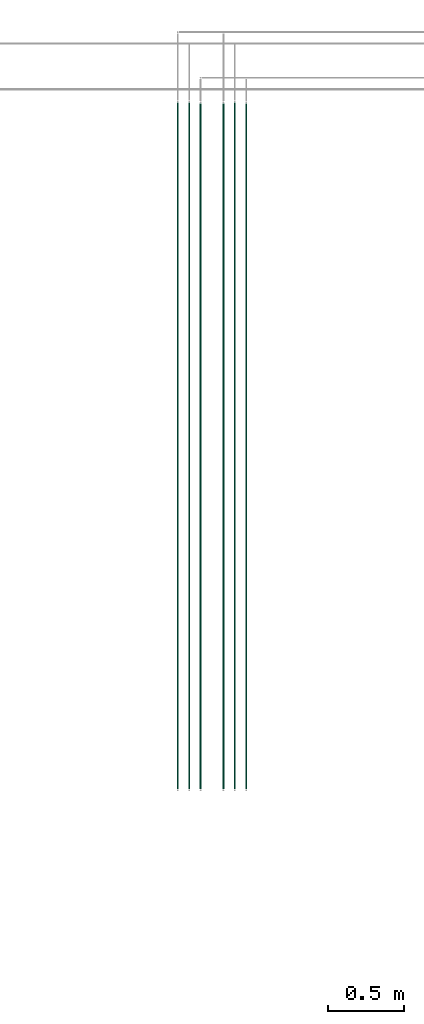
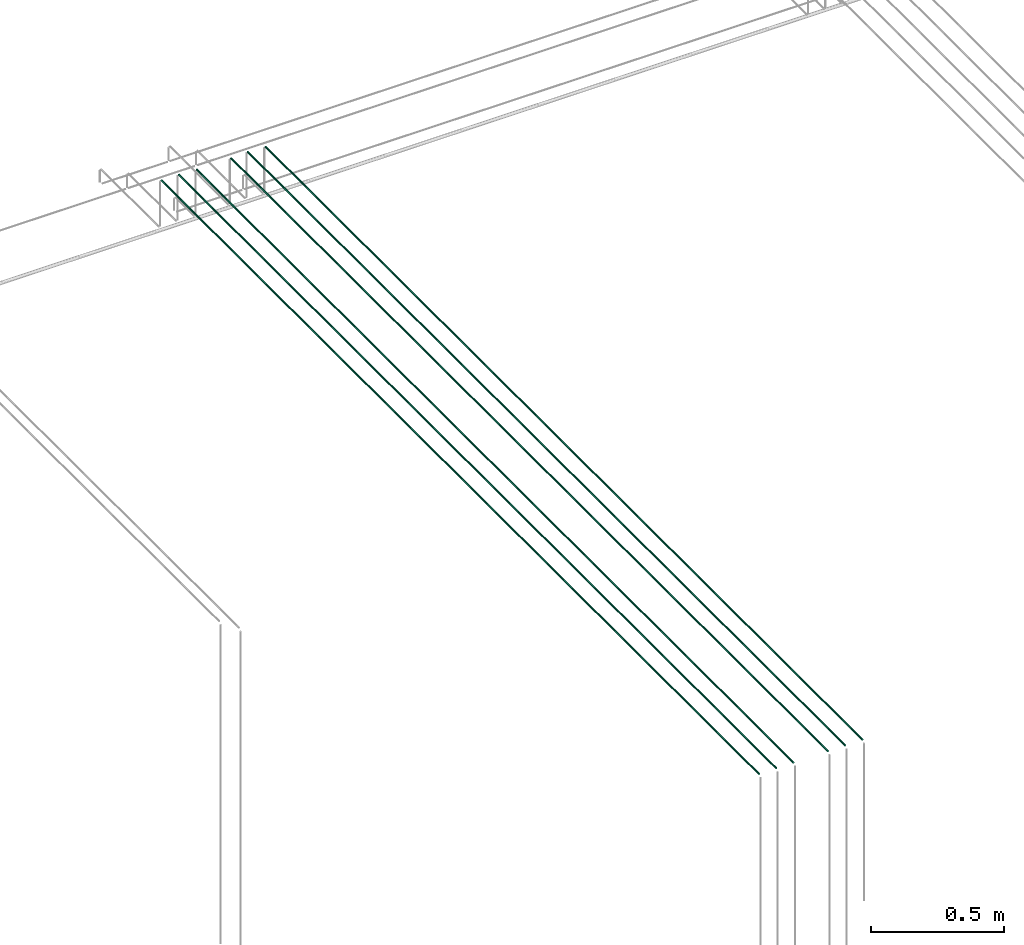
# One storey, part 8 of 89: 6 flow segments.
"""IFC2X3 building model written with IfcOpenShell, lengths in millimetres."""

from ifc_helpers import new_model, entity, si_unit, converted_unit, derived_unit, direction, frame, origin, origin_2d_with_axis, place, context, subcontext, project, spatial, circle, extrude, type_object, element, save


model = new_model("IFC2X3")

# Units and contexts
model_context = context("Model", 3, precision=0.01, world=origin(), true_north=direction((6.12303176911189e-17, 1.0)))
body_context = subcontext(model_context, "Body", "Model", "MODEL_VIEW")
ifc_project = project(units=[si_unit("LENGTHUNIT", "METRE", prefix="MILLI"), si_unit("AREAUNIT", "SQUARE_METRE"), si_unit("VOLUMEUNIT", "CUBIC_METRE"), converted_unit("PLANEANGLEUNIT", "DEGREE", entity("IfcRatioMeasure", 0.0174532925199433), si_unit("PLANEANGLEUNIT", "RADIAN"), dimensions=[0, 0, 0, 0, 0, 0, 0]), si_unit("MASSUNIT", "GRAM", prefix="KILO"), derived_unit("MASSDENSITYUNIT", [(si_unit("MASSUNIT", "GRAM", prefix="KILO"), 1), (si_unit("LENGTHUNIT", "METRE"), -3)]), derived_unit("MOMENTOFINERTIAUNIT", [(si_unit("LENGTHUNIT", "METRE"), 4)]), si_unit("TIMEUNIT", "SECOND"), si_unit("FREQUENCYUNIT", "HERTZ"), si_unit("THERMODYNAMICTEMPERATUREUNIT", "DEGREE_CELSIUS"), derived_unit("THERMALTRANSMITTANCEUNIT", [(si_unit("MASSUNIT", "GRAM", prefix="KILO"), 1), (si_unit("THERMODYNAMICTEMPERATUREUNIT", "KELVIN"), -1), (si_unit("TIMEUNIT", "SECOND"), -3)]), derived_unit("VOLUMETRICFLOWRATEUNIT", [(si_unit("LENGTHUNIT", "METRE"), 3), (si_unit("TIMEUNIT", "SECOND"), -1)]), derived_unit("MASSFLOWRATEUNIT", [(si_unit("MASSUNIT", "GRAM", prefix="KILO"), 1), (si_unit("TIMEUNIT", "SECOND"), -1)]), derived_unit("ROTATIONALFREQUENCYUNIT", [(si_unit("TIMEUNIT", "SECOND"), -1)]), si_unit("ELECTRICCURRENTUNIT", "AMPERE"), si_unit("ELECTRICVOLTAGEUNIT", "VOLT"), si_unit("POWERUNIT", "WATT"), si_unit("FORCEUNIT", "NEWTON", prefix="KILO"), si_unit("ILLUMINANCEUNIT", "LUX"), si_unit("LUMINOUSFLUXUNIT", "LUMEN"), si_unit("LUMINOUSINTENSITYUNIT", "CANDELA"), derived_unit("USERDEFINED", [(si_unit("MASSUNIT", "GRAM", prefix="KILO"), -1), (si_unit("LENGTHUNIT", "METRE"), -2), (si_unit("TIMEUNIT", "SECOND"), 3), (si_unit("LUMINOUSFLUXUNIT", "LUMEN"), 1)]), derived_unit("LINEARVELOCITYUNIT", [(si_unit("LENGTHUNIT", "METRE"), 1), (si_unit("TIMEUNIT", "SECOND"), -1)]), si_unit("PRESSUREUNIT", "PASCAL"), derived_unit("USERDEFINED", [(si_unit("LENGTHUNIT", "METRE"), -2), (si_unit("MASSUNIT", "GRAM", prefix="KILO"), 1), (si_unit("TIMEUNIT", "SECOND"), -2)]), derived_unit("LINEARFORCEUNIT", [(si_unit("MASSUNIT", "GRAM", prefix="KILO"), 1), (si_unit("LENGTHUNIT", "METRE"), 1), (si_unit("TIMEUNIT", "SECOND"), -2), (si_unit("LENGTHUNIT", "METRE"), -1)]), derived_unit("PLANARFORCEUNIT", [(si_unit("MASSUNIT", "GRAM", prefix="KILO"), 1), (si_unit("LENGTHUNIT", "METRE"), 1), (si_unit("TIMEUNIT", "SECOND"), -2), (si_unit("LENGTHUNIT", "METRE"), -2)])], contexts=[model_context])

# Site, building, storey
site_placement = place(None, frame((0.0, -0.00077364408347762, 0.0)))
site = spatial("IfcSite", under=ifc_project, at=site_placement, CompositionType="ELEMENT")
building_placement = place(site_placement, origin())
building = spatial("IfcBuilding", under=site, at=building_placement, CompositionType="ELEMENT")
storey_placement = place(building_placement, frame((0.0, 0.0, 24000.0)))
storey = spatial("IfcBuildingStorey", under=building, at=storey_placement, CompositionType="ELEMENT", Elevation=24000.0)

# Flow segments
pipe_segment_type = type_object("IfcPipeSegmentType", PredefinedType="NOTDEFINED")
flow_segment_1_placement = place(storey_placement, frame((43030.0262171238, 14060.0, 3069.4047277641)))
element("IfcFlowSegment", 1, at=flow_segment_1_placement, inside=storey, type_object=pipe_segment_type, context=body_context, shape_type="SweptSolid", body=[
    extrude(circle(Radius=4.0, at=origin_2d_with_axis()), frame((5.59527223591499, 0.0, 5.59527223591499), z_axis=(0.0, 1.0, 0.0), x_axis=(1.0, 0.0, 0.0)), (0.0, 0.0, 1.0), 4500.00000000001),
])
flow_segment_2_placement = place(storey_placement, frame((43329.7408194806, 14060.0, 3069.4047277641)))
element("IfcFlowSegment", 2, at=flow_segment_2_placement, inside=storey, type_object=pipe_segment_type, context=body_context, shape_type="SweptSolid", body=[
    extrude(circle(Radius=4.0, at=origin_2d_with_axis()), frame((5.59527223591499, 0.0, 5.59527223591499), z_axis=(0.0, 1.0, 0.0), x_axis=(1.0, 0.0, 0.0)), (0.0, 0.0, 1.0), 4495.00000000001),
])
for number, where in (
    (3, (43105.0262171238, 14060.0, 3069.4047277641)),
    (4, (43404.7408194806, 14060.0, 3069.4047277641)),
):
    element("IfcFlowSegment", number, at=place(storey_placement, frame(where)), inside=storey, type_object=pipe_segment_type, context=body_context, shape_type="SweptSolid", body=[
        extrude(circle(Radius=4.0, at=origin_2d_with_axis()), frame((5.59527223591499, 0.0, 5.59527223591499), z_axis=(0.0, 1.0, 0.0), x_axis=(1.0, 0.0, 0.0)), (0.0, 0.0, 1.0), 4500.00000000001),
    ])
for number, where in (
    (5, (43180.0262171238, 14060.0, 3069.4047277641)),
    (6, (43479.7408194806, 14060.0, 3069.4047277641)),
):
    element("IfcFlowSegment", number, at=place(storey_placement, frame(where)), inside=storey, type_object=pipe_segment_type, context=body_context, shape_type="SweptSolid", body=[
        extrude(circle(Radius=4.0, at=origin_2d_with_axis()), frame((5.59527223591499, 0.0, 5.59527223591499), z_axis=(0.0, 1.0, 0.0), x_axis=(1.0, 0.0, 0.0)), (0.0, 0.0, 1.0), 4495.00000000001),
    ])

save(model, "model.ifc")
